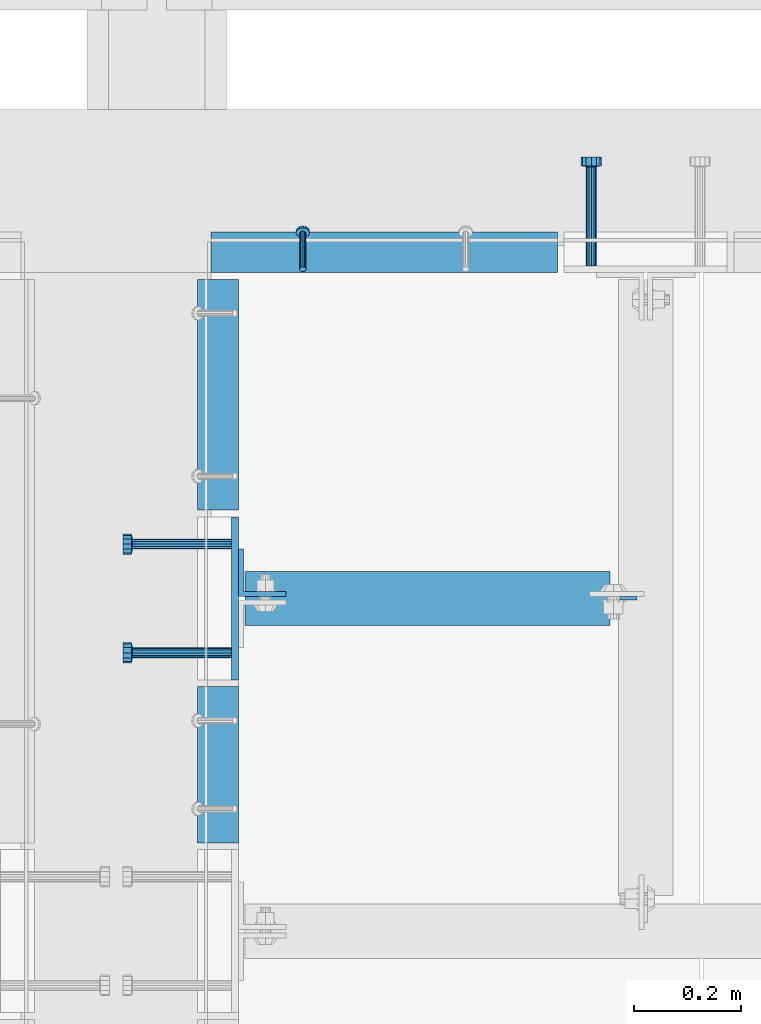
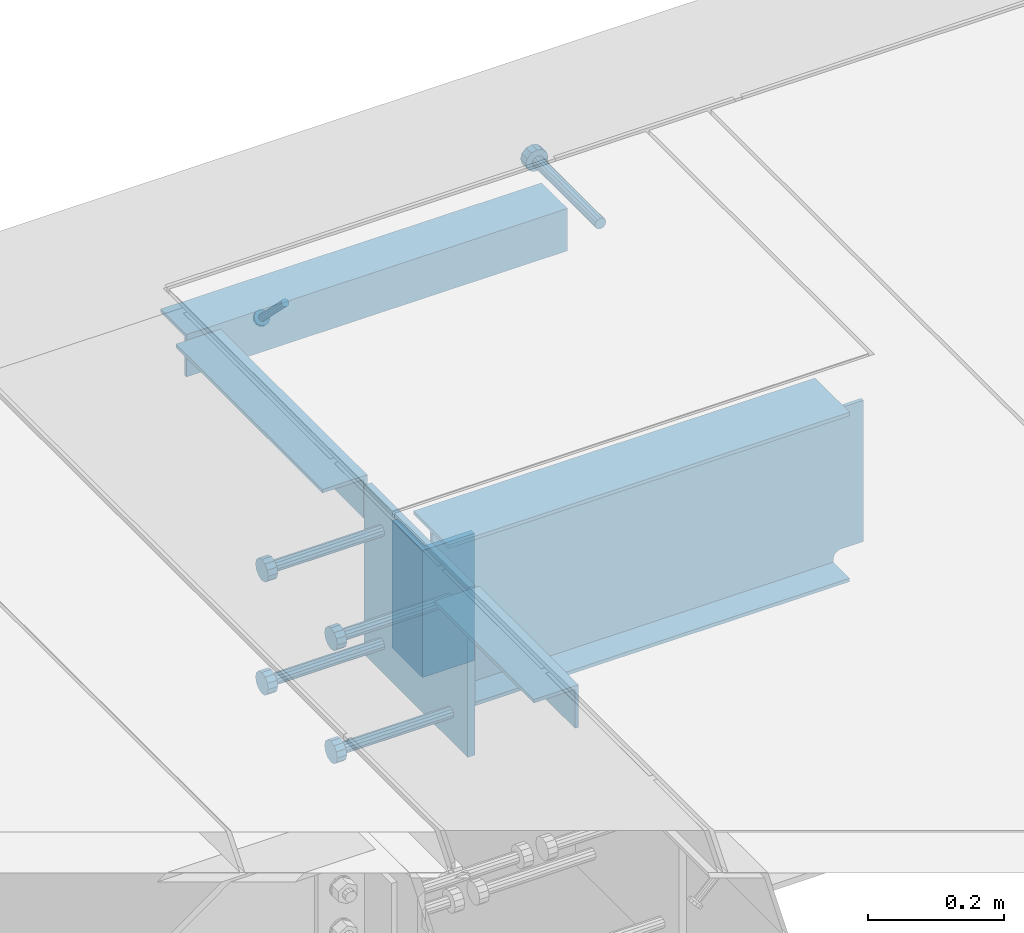
# One storey, part 2150 of 3843: 11 beams, 1 member, 6 elements without a shape of their own.
"""IFC2X3 building model written with IfcOpenShell, lengths in millimetres."""

from ifc_helpers import new_model, si_unit, frame, origin_with_axes, place, context, subcontext, project, spatial, faceted_brep, material, type_object, element, aggregate, save


model = new_model("IFC2X3")

# Units and contexts
model_context = context("Model", 3, precision=1e-05, world=origin_with_axes())
body_context = subcontext(model_context, "Body", "Model", "MODEL_VIEW")
ifc_project = project(units=[si_unit("LENGTHUNIT", "METRE", prefix="MILLI"), si_unit("AREAUNIT", "SQUARE_METRE"), si_unit("VOLUMEUNIT", "CUBIC_METRE"), si_unit("MASSUNIT", "GRAM", prefix="KILO"), si_unit("TIMEUNIT", "SECOND"), si_unit("PLANEANGLEUNIT", "RADIAN"), si_unit("SOLIDANGLEUNIT", "STERADIAN"), si_unit("THERMODYNAMICTEMPERATUREUNIT", "DEGREE_CELSIUS"), si_unit("LUMINOUSINTENSITYUNIT", "LUMEN")], contexts=[model_context])

# Site, building, storey
site_placement = place(None, origin_with_axes())
site = spatial("IfcSite", under=ifc_project, at=site_placement, CompositionType="ELEMENT")
building_placement = place(site_placement, origin_with_axes())
building = spatial("IfcBuilding", under=site, at=building_placement, Name="Undefined", CompositionType="ELEMENT")
storey_placement = place(building_placement, origin_with_axes())
storey = spatial("IfcBuildingStorey", under=building, at=storey_placement, Name="Undefined", CompositionType="ELEMENT", Elevation=0.0)

# Assembly, member
assembly_1_placement = place(storey_placement, origin_with_axes())
assembly_1 = element("IfcElementAssembly", 1, at=assembly_1_placement, inside=storey, Name="ANGLE", AssemblyPlace="NOTDEFINED", PredefinedType="RIGID_FRAME")
ifc_material_1 = material(Name="STEEL/A108")
member_type = type_object("IfcMemberType", PredefinedType="NOTDEFINED")
member_placement = place(assembly_1_placement, frame((62909.4499076102, 18697.5749559954, 30422.8500030518), z_axis=(-1.0, 0.0, 0.0), x_axis=(5.70000238222118e-08, 0.707106781186546, -0.707106781186546)))
member = element("IfcMember", 2, at=member_placement, type_object=member_type, material=ifc_material_1, Name="HEADED STUD ANCHOR", context=body_context, shape_type="Brep", body=[
    faceted_brep([(7.27595761418343e-12, -3.18000006675175, 5.5), (0.0, -5.49999999998363, 3.1800000667572), (94.4879985803855, -5.50000000011278, 3.1800000667572), (94.4879985803782, -3.18000006687362, 5.5), (0.0, -6.3499999046162, 0.0), (94.4879985803855, -6.34999990474535, 0.0), (0.0, -5.49999999998363, -3.1800000667572), (94.4879985803855, -5.50000000011278, -3.1800000667572), (7.27595761418343e-12, -3.18000006675175, -5.5), (94.4879985803782, -3.18000006687362, -5.5), (7.27595761418343e-12, -1.81898940354586e-12, -6.34999990463257), (94.4879985803782, -1.20053300634027e-10, -6.34999990463257), (0.0, 3.18000006675175, -5.5), (94.4879985803709, 3.18000006663351, -5.5), (7.27595761418343e-12, 5.49999999998363, -3.1800000667572), (94.4879985803709, 5.49999999987267, -3.1800000667572), (7.27595761418343e-12, 6.3499999046162, 0.0), (94.4879985803673, 6.34999990450706, 0.0), (7.27595761418343e-12, 5.49999999998363, 3.1800000667572), (94.4879985803709, 5.49999999987267, 3.1800000667572), (0.0, 3.18000006675175, 5.5), (94.4879985803709, 3.18000006663351, 5.5), (7.27595761418343e-12, -1.81898940354586e-12, 6.34999990463257), (94.4879985803782, -1.20053300634027e-10, 6.34999990463257), (96.5199985498621, -10.9899997712273, 6.34999990463257), (96.5199985498548, -6.34000015270249, 10.9899997711182), (96.5199985498621, -12.6999998093743, 0.0), (96.5199985498621, -10.9899997712273, -6.34999990463257), (96.5199985498548, -6.34000015270249, -10.9899997711182), (96.5199985498475, -1.21872290037572e-10, -12.6899995803833), (96.5199985498402, 6.34000015245874, -10.9899997711182), (96.519998549833, 10.9899997709817, -6.34999990463257), (96.519998549833, 12.6999998091305, 0.0), (96.519998549833, 10.9899997709817, 6.34999990463257), (96.5199985498402, 6.34000015245874, 10.9899997711182), (96.5199985498475, -1.21872290037572e-10, 12.6899995803833), (101.599998473539, -10.9899997712328, 6.34999990463257), (101.599998473532, -6.34000015270976, 10.9899997711182), (101.599998473539, -12.6999998093797, 0.0), (101.599998473539, -10.9899997712328, -6.34999990463257), (101.599998473532, -6.34000015270976, -10.9899997711182), (101.599998473524, -1.29148247651756e-10, -12.6899995803833), (101.599998473517, 6.34000015245329, -10.9899997711182), (101.59999847351, 10.9899997709763, -6.34999990463257), (101.599998473503, 12.6999998091196, 0.0), (101.59999847351, 10.9899997709763, 6.34999990463257), (101.599998473517, 6.34000015245329, 10.9899997711182), (101.599998473524, -1.29148247651756e-10, 12.6899995803833)], [[[0, 1, 2, 3]], [[1, 4, 5, 2]], [[4, 6, 7, 5]], [[6, 8, 9, 7]], [[8, 10, 11, 9]], [[10, 12, 13, 11]], [[12, 14, 15, 13]], [[14, 16, 17, 15]], [[16, 18, 19, 17]], [[18, 20, 21, 19]], [[20, 22, 23, 21]], [[22, 0, 3, 23]], [[22, 20, 18, 16, 14, 12, 10, 8, 6, 4, 1, 0]], [[3, 2, 24, 25]], [[2, 5, 26, 24]], [[5, 7, 27, 26]], [[7, 9, 28, 27]], [[9, 11, 29, 28]], [[11, 13, 30, 29]], [[13, 15, 31, 30]], [[15, 17, 32, 31]], [[17, 19, 33, 32]], [[19, 21, 34, 33]], [[21, 23, 35, 34]], [[23, 3, 25, 35]], [[25, 24, 36, 37]], [[24, 26, 38, 36]], [[26, 27, 39, 38]], [[27, 28, 40, 39]], [[28, 29, 41, 40]], [[29, 30, 42, 41]], [[30, 31, 43, 42]], [[31, 32, 44, 43]], [[32, 33, 45, 44]], [[33, 34, 46, 45]], [[34, 35, 47, 46]], [[35, 25, 37, 47]], [[38, 39, 40, 41, 42, 43, 44, 45, 46, 47, 37, 36]]]),
])

# Assembly, beam
assembly_2_placement = place(storey_placement, origin_with_axes())
assembly_2 = element("IfcElementAssembly", 3, at=assembly_2_placement, inside=storey, Name="EMBED PLATE", AssemblyPlace="NOTDEFINED", PredefinedType="RIGID_FRAME")
ifc_material_2 = material(Name="STEEL/A36")
beam_type_1 = type_object("IfcBeamType", PredefinedType="NOTDEFINED")
beam_1_placement = place(assembly_2_placement, frame((62782.4500030517, 18081.625, 30422.85), z_axis=(0.0, 1.0, 0.0), x_axis=(0.0, 0.0, -1.0)))
beam_1 = element("IfcBeam", 4, at=beam_1_placement, type_object=beam_type_1, material=ifc_material_2, Name="EMBED PLATE", context=body_context, shape_type="Brep", body=[
    faceted_brep([(-1.0550138540566e-10, 6.34999999999854, -152.400000000664), (1.0550138540566e-10, 6.34999999999854, 152.400000000656), (304.799999999999, 6.34999999999854, 152.400000000001), (304.799999999999, 6.34999999999854, -152.400000000001), (1.0550138540566e-10, -6.34999999999854, 152.400000000656), (304.799999999999, -6.34999999999854, 152.400000000001), (-1.0550138540566e-10, -6.34999999999854, -152.400000000664), (304.799999999999, -6.34999999999854, -152.400000000001)], [[[0, 1, 2, 3]], [[1, 4, 5, 2]], [[4, 6, 7, 5]], [[6, 0, 3, 7]], [[5, 7, 3, 2]], [[6, 4, 1, 0]]]),
])

assembly_3_placement = place(storey_placement, origin_with_axes())
assembly_3 = element("IfcElementAssembly", 5, at=assembly_3_placement, inside=storey, Name="ANGLE", AssemblyPlace="NOTDEFINED", PredefinedType="RIGID_FRAME")
beam_type_2 = type_object("IfcBeamType", Name="L3X3X1/4", PredefinedType="NOTDEFINED")
beam_2_placement = place(assembly_3_placement, frame((62750.6999970423, 17624.4250731787, 30391.1000045777), z_axis=(0.0, 0.0, -1.0), x_axis=(0.0, 1.0, 0.0)))
beam_2 = element("IfcBeam", 6, at=beam_2_placement, type_object=beam_type_2, material=ifc_material_2, Name="ANGLE", ObjectType="L3X3X1/4", context=body_context, shape_type="Brep", body=[
    faceted_brep([(0.0, 38.0999999999985, -38.0999999999985), (0.0, 38.0999999999985, 38.0999999999985), (292.099926759005, 38.0999999991764, 38.0999999999985), (292.099926759005, 38.0999999991764, -38.0999999999985), (0.0, 31.75, 38.0999999999985), (292.099926759009, 31.7499999991778, 38.0999999999985), (0.0, 31.75, -31.75), (292.099926759009, 31.7499999991778, -31.75), (0.0, -38.0999999999985, -31.75), (292.099926759067, -38.1000000008207, -31.75), (0.0, -38.0999999999985, -38.0999999999985), (292.099926759067, -38.1000000008207, -38.0999999999985)], [[[0, 1, 2, 3]], [[1, 4, 5, 2]], [[4, 6, 7, 5]], [[6, 8, 9, 7]], [[8, 10, 11, 9]], [[10, 0, 3, 11]], [[5, 7, 9, 11, 3, 2]], [[10, 8, 6, 4, 1, 0]]]),
])
aggregate(assembly_3, [beam_2])

# Beam
beam_3_placement = place(assembly_1_placement, frame((62737.999868244, 18729.324900916, 30391.1000030518), z_axis=(0.0, 0.0, -1.0), x_axis=(1.0, 0.0, 0.0)))
beam_3 = element("IfcBeam", 7, at=beam_3_placement, type_object=beam_type_2, material=ifc_material_2, Name="ANGLE", ObjectType="L3X3X1/4", context=body_context, shape_type="Brep", body=[
    faceted_brep([(0.0, 38.0999999999985, -38.0999999999985), (0.0, 38.0999999999985, 38.0999999999985), (647.700078732363, 38.0999999999985, 38.0999999999985), (647.700078732363, 38.0999999999985, -38.0999999999985), (0.0, 31.75, 38.0999999999985), (647.700078732363, 31.75, 38.0999999999985), (0.0, 31.75, -31.75), (647.700078732363, 31.75, -31.75), (0.0, -38.0999999999985, -31.75), (647.700078732363, -38.0999999999985, -31.75), (0.0, -38.0999999999985, -38.0999999999985), (647.700078732363, -38.0999999999985, -38.0999999999985)], [[[0, 1, 2, 3]], [[1, 4, 5, 2]], [[4, 6, 7, 5]], [[6, 8, 9, 7]], [[8, 10, 11, 9]], [[10, 0, 3, 11]], [[5, 7, 9, 11, 3, 2]], [[10, 8, 6, 4, 1, 0]]]),
])

aggregate(assembly_1, [member, beam_3])

# Assembly, beam
assembly_4_placement = place(storey_placement, origin_with_axes())
assembly_4 = element("IfcElementAssembly", 8, at=assembly_4_placement, inside=storey, Name="ANGLE", AssemblyPlace="NOTDEFINED", PredefinedType="RIGID_FRAME")
beam_4_placement = place(assembly_4_placement, frame((62750.6999970423, 18246.7250002667, 30391.1000045777), z_axis=(0.0, 0.0, -1.0), x_axis=(0.0, 1.0, 0.0)))
beam_4 = element("IfcBeam", 9, at=beam_4_placement, type_object=beam_type_2, material=ifc_material_2, Name="ANGLE", ObjectType="L3X3X1/4", context=body_context, shape_type="Brep", body=[
    faceted_brep([(0.0, 38.0999999999985, -38.0999999999985), (0.0, 38.0999999999985, 38.0999999999985), (431.800000000025, 38.0999999997803, 38.0999999999985), (431.800000000025, 38.0999999997803, -38.0999999999985), (0.0, 31.75, 38.0999999999985), (431.800000000021, 31.7499999997817, 38.0999999999985), (0.0, 31.75, -31.75), (431.800000000021, 31.7499999997817, -31.75), (0.0, -38.0999999999985, -31.75), (431.799999999981, -38.1000000002241, -31.75), (0.0, -38.0999999999985, -38.0999999999985), (431.799999999981, -38.1000000002241, -38.0999999999985)], [[[0, 1, 2, 3]], [[1, 4, 5, 2]], [[4, 6, 7, 5]], [[6, 8, 9, 7]], [[8, 10, 11, 9]], [[10, 0, 3, 11]], [[5, 7, 9, 11, 3, 2]], [[10, 8, 6, 4, 1, 0]]]),
])
aggregate(assembly_4, [beam_4])

assembly_5_placement = place(storey_placement, origin_with_axes())
assembly_5 = element("IfcElementAssembly", 10, at=assembly_5_placement, inside=storey, Name="BEAM", AssemblyPlace="NOTDEFINED", PredefinedType="RIGID_FRAME")
beam_type_3 = type_object("IfcBeamType", Name="L3-1/2X3-1/2X3/8", PredefinedType="NOTDEFINED")
beam_5_placement = place(assembly_5_placement, frame((62833.2500030518, 18129.25, 30391.1), z_axis=(0.0, 1.0, 0.0), x_axis=(0.0, 0.0, -1.0)))
beam_5 = element("IfcBeam", 11, at=beam_5_placement, type_object=beam_type_3, material=ifc_material_2, Name="ANGLE", ObjectType="L3-1/2X3-1/2X3/8", context=body_context, shape_type="Brep", body=[
    faceted_brep([(-3.63797880709171e-12, 44.4499999999971, -44.4500000000007), (-3.63797880709171e-12, 44.4499999999971, 44.4500000000007), (228.600000000006, 44.4499999999971, 44.4500000000007), (228.600000000006, 44.4499999999971, -44.4500000000007), (0.0, 34.9250000000029, 44.4500000000007), (228.600000000006, 34.9250000000029, 44.4500000000007), (0.0, 34.9250000000029, -34.9250000000029), (228.600000000006, 34.9250000000029, -34.9249999999993), (0.0, -44.4499999999971, -34.9249999999993), (228.600000000006, -44.4499999999971, -34.9249999999993), (3.63797880709171e-12, -44.4499999999971, -44.4500000000007), (228.600000000006, -44.4499999999971, -44.4500000000007)], [[[0, 1, 2, 3]], [[1, 4, 5, 2]], [[4, 6, 7, 5]], [[6, 8, 9, 7]], [[8, 10, 11, 9]], [[10, 0, 3, 11]], [[5, 7, 9, 11, 3, 2]], [[10, 8, 6, 4, 1, 0]]]),
])

# Beam
beam_type_4 = type_object("IfcBeamType", PredefinedType="NOTDEFINED")
beam_6_placement = place(assembly_2_placement, frame((62776.1000030517, 17980.025, 30372.05), z_axis=(0.0, -1.0, 0.0), x_axis=(-1.0, 0.0, 0.0)))
beam_6 = element("IfcBeam", 12, at=beam_6_placement, type_object=beam_type_4, material=ifc_material_1, Name="HEADED STUD ANCHOR", context=body_context, shape_type="Brep", body=[
    faceted_brep([(0.0, -9.52000045776367, 0.0), (0.0, -8.25, -4.76000022888184), (184.912000000004, -8.25, -4.76000022888184), (184.912000000004, -9.52000045776367, 0.0), (0.0, -4.76000022888184, -8.25), (184.912000000004, -4.76000022888184, -8.25), (0.0, 0.0, -9.52000045776367), (184.912000000004, 0.0, -9.52000045776367), (0.0, 4.76000022888184, -8.25), (184.912000000004, 4.76000022888184, -8.25), (0.0, 8.25, -4.76000022888184), (184.912000000004, 8.25, -4.76000022888184), (0.0, 9.52000045776367, 0.0), (184.912000000004, 9.52000045776367, 0.0), (0.0, 8.25, 4.76000022888184), (184.912000000004, 8.25, 4.76000022888184), (0.0, 4.76000022888184, 8.25), (184.912000000004, 4.76000022888184, 8.25), (0.0, 0.0, 9.52000045776367), (184.912000000004, 0.0, 9.52000045776367), (0.0, -4.76000022888184, 8.25), (184.912000000004, -4.76000022888184, 8.25), (0.0, -8.25, 4.76000022888184), (184.912000000004, -8.25, 4.76000022888184), (186.944000000003, -16.5, -9.52000045776367), (186.944000000003, -19.0499992370605, 0.0), (186.944000000003, -9.52000045776367, -16.5), (186.944000000003, 0.0, -19.0499992370605), (186.944000000003, 9.52000045776367, -16.5), (186.944000000003, 16.5, -9.52000045776367), (186.944000000003, 19.0499992370605, 0.0), (186.944000000003, 16.5, 9.52000045776367), (186.944000000003, 9.52000045776367, 16.5), (186.944000000003, 0.0, 19.0499992370605), (186.944000000003, -9.52000045776367, 16.5), (186.944000000003, -16.5, 9.52000045776367), (203.199999999997, -16.5, -9.52000045776367), (203.199999999997, -19.0499992370605, 0.0), (203.199999999997, -9.52000045776367, -16.5), (203.199999999997, 0.0, -19.0499992370605), (203.199999999997, 9.52000045776367, -16.5), (203.199999999997, 16.5, -9.52000045776367), (203.199999999997, 19.0499992370605, 0.0), (203.199999999997, 16.5, 9.52000045776367), (203.199999999997, 9.52000045776367, 16.5), (203.199999999997, 0.0, 19.0499992370605), (203.199999999997, -9.52000045776367, 16.5), (203.199999999997, -16.5, 9.52000045776367)], [[[0, 1, 2, 3]], [[1, 4, 5, 2]], [[4, 6, 7, 5]], [[6, 8, 9, 7]], [[8, 10, 11, 9]], [[10, 12, 13, 11]], [[12, 14, 15, 13]], [[14, 16, 17, 15]], [[16, 18, 19, 17]], [[18, 20, 21, 19]], [[20, 22, 23, 21]], [[22, 0, 3, 23]], [[22, 20, 18, 16, 14, 12, 10, 8, 6, 4, 1, 0]], [[3, 2, 24, 25]], [[2, 5, 26, 24]], [[5, 7, 27, 26]], [[7, 9, 28, 27]], [[9, 11, 29, 28]], [[11, 13, 30, 29]], [[13, 15, 31, 30]], [[15, 17, 32, 31]], [[17, 19, 33, 32]], [[19, 21, 34, 33]], [[21, 23, 35, 34]], [[23, 3, 25, 35]], [[25, 24, 36, 37]], [[24, 26, 38, 36]], [[26, 27, 39, 38]], [[27, 28, 40, 39]], [[28, 29, 41, 40]], [[29, 30, 42, 41]], [[30, 31, 43, 42]], [[31, 32, 44, 43]], [[32, 33, 45, 44]], [[33, 34, 46, 45]], [[34, 35, 47, 46]], [[35, 25, 37, 47]], [[38, 39, 40, 41, 42, 43, 44, 45, 46, 47, 37, 36]]]),
])

beam_7_placement = place(assembly_2_placement, frame((62776.1000030517, 17980.025, 30168.85), z_axis=(0.0, -1.0, 0.0), x_axis=(-1.0, 0.0, 0.0)))
beam_7 = element("IfcBeam", 13, at=beam_7_placement, type_object=beam_type_4, material=ifc_material_1, Name="HEADED STUD ANCHOR", context=body_context, shape_type="Brep", body=[
    faceted_brep([(0.0, -9.52000045776367, 0.0), (0.0, -8.25, -4.76000022888184), (184.912000000004, -8.25, -4.76000022888184), (184.912000000004, -9.52000045776367, 0.0), (0.0, -4.76000022888184, -8.25), (184.912000000004, -4.76000022888184, -8.25), (0.0, 0.0, -9.52000045776367), (184.912000000004, 0.0, -9.52000045776367), (0.0, 4.76000022888184, -8.25), (184.912000000004, 4.76000022888184, -8.25), (0.0, 8.25, -4.76000022888184), (184.912000000004, 8.25, -4.76000022888184), (0.0, 9.52000045776367, 0.0), (184.912000000004, 9.52000045776367, 0.0), (0.0, 8.25, 4.76000022888184), (184.912000000004, 8.25, 4.76000022888184), (0.0, 4.76000022888184, 8.25), (184.912000000004, 4.76000022888184, 8.25), (0.0, 0.0, 9.52000045776367), (184.912000000004, 0.0, 9.52000045776367), (0.0, -4.76000022888184, 8.25), (184.912000000004, -4.76000022888184, 8.25), (0.0, -8.25, 4.76000022888184), (184.912000000004, -8.25, 4.76000022888184), (186.944000000003, -16.5, -9.52000045776367), (186.944000000003, -19.0499992370605, 0.0), (186.944000000003, -9.52000045776367, -16.5), (186.944000000003, 0.0, -19.0499992370605), (186.944000000003, 9.52000045776367, -16.5), (186.944000000003, 16.5, -9.52000045776367), (186.944000000003, 19.0499992370605, 0.0), (186.944000000003, 16.5, 9.52000045776367), (186.944000000003, 9.52000045776367, 16.5), (186.944000000003, 0.0, 19.0499992370605), (186.944000000003, -9.52000045776367, 16.5), (186.944000000003, -16.5, 9.52000045776367), (203.199999999997, -16.5, -9.52000045776367), (203.199999999997, -19.0499992370605, 0.0), (203.199999999997, -9.52000045776367, -16.5), (203.199999999997, 0.0, -19.0499992370605), (203.199999999997, 9.52000045776367, -16.5), (203.199999999997, 16.5, -9.52000045776367), (203.199999999997, 19.0499992370605, 0.0), (203.199999999997, 16.5, 9.52000045776367), (203.199999999997, 9.52000045776367, 16.5), (203.199999999997, 0.0, 19.0499992370605), (203.199999999997, -9.52000045776367, 16.5), (203.199999999997, -16.5, 9.52000045776367)], [[[0, 1, 2, 3]], [[1, 4, 5, 2]], [[4, 6, 7, 5]], [[6, 8, 9, 7]], [[8, 10, 11, 9]], [[10, 12, 13, 11]], [[12, 14, 15, 13]], [[14, 16, 17, 15]], [[16, 18, 19, 17]], [[18, 20, 21, 19]], [[20, 22, 23, 21]], [[22, 0, 3, 23]], [[22, 20, 18, 16, 14, 12, 10, 8, 6, 4, 1, 0]], [[3, 2, 24, 25]], [[2, 5, 26, 24]], [[5, 7, 27, 26]], [[7, 9, 28, 27]], [[9, 11, 29, 28]], [[11, 13, 30, 29]], [[13, 15, 31, 30]], [[15, 17, 32, 31]], [[17, 19, 33, 32]], [[19, 21, 34, 33]], [[21, 23, 35, 34]], [[23, 3, 25, 35]], [[25, 24, 36, 37]], [[24, 26, 38, 36]], [[26, 27, 39, 38]], [[27, 28, 40, 39]], [[28, 29, 41, 40]], [[29, 30, 42, 41]], [[30, 31, 43, 42]], [[31, 32, 44, 43]], [[32, 33, 45, 44]], [[33, 34, 46, 45]], [[34, 35, 47, 46]], [[35, 25, 37, 47]], [[38, 39, 40, 41, 42, 43, 44, 45, 46, 47, 37, 36]]]),
])

beam_8_placement = place(assembly_2_placement, frame((62776.1000030517, 18183.225, 30372.05), z_axis=(0.0, -1.0, 0.0), x_axis=(-1.0, 0.0, 0.0)))
beam_8 = element("IfcBeam", 14, at=beam_8_placement, type_object=beam_type_4, material=ifc_material_2, Name="PLATE", context=body_context, shape_type="Brep", body=[
    faceted_brep([(0.0, -9.52000045776367, 0.0), (0.0, -8.25, -4.76000022888184), (184.912000000004, -8.25, -4.76000022888184), (184.912000000004, -9.52000045776367, 0.0), (0.0, -4.76000022888184, -8.25), (184.912000000004, -4.76000022888184, -8.25), (0.0, 0.0, -9.52000045776367), (184.912000000004, 0.0, -9.52000045776367), (0.0, 4.76000022888184, -8.25), (184.912000000004, 4.76000022888184, -8.25), (0.0, 8.25, -4.76000022888184), (184.912000000004, 8.25, -4.76000022888184), (0.0, 9.52000045776367, 0.0), (184.912000000004, 9.52000045776367, 0.0), (0.0, 8.25, 4.76000022888184), (184.912000000004, 8.25, 4.76000022888184), (0.0, 4.76000022888184, 8.25), (184.912000000004, 4.76000022888184, 8.25), (0.0, 0.0, 9.52000045776367), (184.912000000004, 0.0, 9.52000045776367), (0.0, -4.76000022888184, 8.25), (184.912000000004, -4.76000022888184, 8.25), (0.0, -8.25, 4.76000022888184), (184.912000000004, -8.25, 4.76000022888184), (186.944000000003, -16.5, -9.52000045776367), (186.944000000003, -19.0499992370605, 0.0), (186.944000000003, -9.52000045776367, -16.5), (186.944000000003, 0.0, -19.0499992370605), (186.944000000003, 9.52000045776367, -16.5), (186.944000000003, 16.5, -9.52000045776367), (186.944000000003, 19.0499992370605, 0.0), (186.944000000003, 16.5, 9.52000045776367), (186.944000000003, 9.52000045776367, 16.5), (186.944000000003, 0.0, 19.0499992370605), (186.944000000003, -9.52000045776367, 16.5), (186.944000000003, -16.5, 9.52000045776367), (203.199999999997, -16.5, -9.52000045776367), (203.199999999997, -19.0499992370605, 0.0), (203.199999999997, -9.52000045776367, -16.5), (203.199999999997, 0.0, -19.0499992370605), (203.199999999997, 9.52000045776367, -16.5), (203.199999999997, 16.5, -9.52000045776367), (203.199999999997, 19.0499992370605, 0.0), (203.199999999997, 16.5, 9.52000045776367), (203.199999999997, 9.52000045776367, 16.5), (203.199999999997, 0.0, 19.0499992370605), (203.199999999997, -9.52000045776367, 16.5), (203.199999999997, -16.5, 9.52000045776367)], [[[0, 1, 2, 3]], [[1, 4, 5, 2]], [[4, 6, 7, 5]], [[6, 8, 9, 7]], [[8, 10, 11, 9]], [[10, 12, 13, 11]], [[12, 14, 15, 13]], [[14, 16, 17, 15]], [[16, 18, 19, 17]], [[18, 20, 21, 19]], [[20, 22, 23, 21]], [[22, 0, 3, 23]], [[22, 20, 18, 16, 14, 12, 10, 8, 6, 4, 1, 0]], [[3, 2, 24, 25]], [[2, 5, 26, 24]], [[5, 7, 27, 26]], [[7, 9, 28, 27]], [[9, 11, 29, 28]], [[11, 13, 30, 29]], [[13, 15, 31, 30]], [[15, 17, 32, 31]], [[17, 19, 33, 32]], [[19, 21, 34, 33]], [[21, 23, 35, 34]], [[23, 3, 25, 35]], [[25, 24, 36, 37]], [[24, 26, 38, 36]], [[26, 27, 39, 38]], [[27, 28, 40, 39]], [[28, 29, 41, 40]], [[29, 30, 42, 41]], [[30, 31, 43, 42]], [[31, 32, 44, 43]], [[32, 33, 45, 44]], [[33, 34, 46, 45]], [[34, 35, 47, 46]], [[35, 25, 37, 47]], [[38, 39, 40, 41, 42, 43, 44, 45, 46, 47, 37, 36]]]),
])

beam_9_placement = place(assembly_2_placement, frame((62776.1000030517, 18183.225, 30168.85), z_axis=(0.0, -1.0, 0.0), x_axis=(-1.0, 0.0, 0.0)))
beam_9 = element("IfcBeam", 15, at=beam_9_placement, type_object=beam_type_4, material=ifc_material_1, Name="HEADED STUD ANCHOR", context=body_context, shape_type="Brep", body=[
    faceted_brep([(0.0, -9.52000045776367, 0.0), (0.0, -8.25, -4.76000022888184), (184.912000000004, -8.25, -4.76000022888184), (184.912000000004, -9.52000045776367, 0.0), (0.0, -4.76000022888184, -8.25), (184.912000000004, -4.76000022888184, -8.25), (0.0, 0.0, -9.52000045776367), (184.912000000004, 0.0, -9.52000045776367), (0.0, 4.76000022888184, -8.25), (184.912000000004, 4.76000022888184, -8.25), (0.0, 8.25, -4.76000022888184), (184.912000000004, 8.25, -4.76000022888184), (0.0, 9.52000045776367, 0.0), (184.912000000004, 9.52000045776367, 0.0), (0.0, 8.25, 4.76000022888184), (184.912000000004, 8.25, 4.76000022888184), (0.0, 4.76000022888184, 8.25), (184.912000000004, 4.76000022888184, 8.25), (0.0, 0.0, 9.52000045776367), (184.912000000004, 0.0, 9.52000045776367), (0.0, -4.76000022888184, 8.25), (184.912000000004, -4.76000022888184, 8.25), (0.0, -8.25, 4.76000022888184), (184.912000000004, -8.25, 4.76000022888184), (186.944000000003, -16.5, -9.52000045776367), (186.944000000003, -19.0499992370605, 0.0), (186.944000000003, -9.52000045776367, -16.5), (186.944000000003, 0.0, -19.0499992370605), (186.944000000003, 9.52000045776367, -16.5), (186.944000000003, 16.5, -9.52000045776367), (186.944000000003, 19.0499992370605, 0.0), (186.944000000003, 16.5, 9.52000045776367), (186.944000000003, 9.52000045776367, 16.5), (186.944000000003, 0.0, 19.0499992370605), (186.944000000003, -9.52000045776367, 16.5), (186.944000000003, -16.5, 9.52000045776367), (203.199999999997, -16.5, -9.52000045776367), (203.199999999997, -19.0499992370605, 0.0), (203.199999999997, -9.52000045776367, -16.5), (203.199999999997, 0.0, -19.0499992370605), (203.199999999997, 9.52000045776367, -16.5), (203.199999999997, 16.5, -9.52000045776367), (203.199999999997, 19.0499992370605, 0.0), (203.199999999997, 16.5, 9.52000045776367), (203.199999999997, 9.52000045776367, 16.5), (203.199999999997, 0.0, 19.0499992370605), (203.199999999997, -9.52000045776367, 16.5), (203.199999999997, -16.5, 9.52000045776367)], [[[0, 1, 2, 3]], [[1, 4, 5, 2]], [[4, 6, 7, 5]], [[6, 8, 9, 7]], [[8, 10, 11, 9]], [[10, 12, 13, 11]], [[12, 14, 15, 13]], [[14, 16, 17, 15]], [[16, 18, 19, 17]], [[18, 20, 21, 19]], [[20, 22, 23, 21]], [[22, 0, 3, 23]], [[22, 20, 18, 16, 14, 12, 10, 8, 6, 4, 1, 0]], [[3, 2, 24, 25]], [[2, 5, 26, 24]], [[5, 7, 27, 26]], [[7, 9, 28, 27]], [[9, 11, 29, 28]], [[11, 13, 30, 29]], [[13, 15, 31, 30]], [[15, 17, 32, 31]], [[17, 19, 33, 32]], [[19, 21, 34, 33]], [[21, 23, 35, 34]], [[23, 3, 25, 35]], [[25, 24, 36, 37]], [[24, 26, 38, 36]], [[26, 27, 39, 38]], [[27, 28, 40, 39]], [[28, 29, 41, 40]], [[29, 30, 42, 41]], [[30, 31, 43, 42]], [[31, 32, 44, 43]], [[32, 33, 45, 44]], [[33, 34, 46, 45]], [[34, 35, 47, 46]], [[35, 25, 37, 47]], [[38, 39, 40, 41, 42, 43, 44, 45, 46, 47, 37, 36]]]),
])

aggregate(assembly_2, [beam_6, beam_7, beam_8, beam_9, beam_1])

# Assembly, beam
assembly_6_placement = place(storey_placement, origin_with_axes())
assembly_6 = element("IfcElementAssembly", 16, at=assembly_6_placement, inside=storey, Name="EMBED PLATE", AssemblyPlace="NOTDEFINED", PredefinedType="RIGID_FRAME")
beam_10_placement = place(assembly_6_placement, frame((63449.2, 18703.9249969482, 30372.05), z_axis=(-1.0, 0.0, 0.0), x_axis=(0.0, 1.0, 0.0)))
beam_10 = element("IfcBeam", 17, at=beam_10_placement, type_object=beam_type_4, material=ifc_material_1, Name="HEADED STUD ANCHOR", context=body_context, shape_type="Brep", body=[
    faceted_brep([(0.0, -9.52000045776367, 0.0), (0.0, -8.25, -4.76000022888184), (184.912000000004, -8.25, -4.76000022888184), (184.912000000004, -9.52000045776367, 0.0), (0.0, -4.76000022888184, -8.25), (184.912000000004, -4.76000022888184, -8.25), (0.0, 0.0, -9.52000045776367), (184.912000000004, 0.0, -9.52000045776367), (0.0, 4.76000022888184, -8.25), (184.912000000004, 4.76000022888184, -8.25), (0.0, 8.25, -4.76000022888184), (184.912000000004, 8.25, -4.76000022888184), (0.0, 9.52000045776367, 0.0), (184.912000000004, 9.52000045776367, 0.0), (0.0, 8.25, 4.76000022888184), (184.912000000004, 8.25, 4.76000022888184), (0.0, 4.76000022888184, 8.25), (184.912000000004, 4.76000022888184, 8.25), (0.0, 0.0, 9.52000045776367), (184.912000000004, 0.0, 9.52000045776367), (0.0, -4.76000022888184, 8.25), (184.912000000004, -4.76000022888184, 8.25), (0.0, -8.25, 4.76000022888184), (184.912000000004, -8.25, 4.76000022888184), (186.944000000003, -16.5, -9.52000045776367), (186.944000000003, -19.0499992370605, 0.0), (186.944000000003, -9.52000045776367, -16.5), (186.944000000003, 0.0, -19.0499992370605), (186.944000000003, 9.52000045776367, -16.5), (186.944000000003, 16.5, -9.52000045776367), (186.944000000003, 19.0499992370605, 0.0), (186.944000000003, 16.5, 9.52000045776367), (186.944000000003, 9.52000045776367, 16.5), (186.944000000003, 0.0, 19.0499992370605), (186.944000000003, -9.52000045776367, 16.5), (186.944000000003, -16.5, 9.52000045776367), (203.199999999997, -16.5, -9.52000045776367), (203.199999999997, -19.0499992370605, 0.0), (203.199999999997, -9.52000045776367, -16.5), (203.199999999997, 0.0, -19.0499992370605), (203.199999999997, 9.52000045776367, -16.5), (203.199999999997, 16.5, -9.52000045776367), (203.199999999997, 19.0499992370605, 0.0), (203.199999999997, 16.5, 9.52000045776367), (203.199999999997, 9.52000045776367, 16.5), (203.199999999997, 0.0, 19.0499992370605), (203.199999999997, -9.52000045776367, 16.5), (203.199999999997, -16.5, 9.52000045776367)], [[[0, 1, 2, 3]], [[1, 4, 5, 2]], [[4, 6, 7, 5]], [[6, 8, 9, 7]], [[8, 10, 11, 9]], [[10, 12, 13, 11]], [[12, 14, 15, 13]], [[14, 16, 17, 15]], [[16, 18, 19, 17]], [[18, 20, 21, 19]], [[20, 22, 23, 21]], [[22, 0, 3, 23]], [[22, 20, 18, 16, 14, 12, 10, 8, 6, 4, 1, 0]], [[3, 2, 24, 25]], [[2, 5, 26, 24]], [[5, 7, 27, 26]], [[7, 9, 28, 27]], [[9, 11, 29, 28]], [[11, 13, 30, 29]], [[13, 15, 31, 30]], [[15, 17, 32, 31]], [[17, 19, 33, 32]], [[19, 21, 34, 33]], [[21, 23, 35, 34]], [[23, 3, 25, 35]], [[25, 24, 36, 37]], [[24, 26, 38, 36]], [[26, 27, 39, 38]], [[27, 28, 40, 39]], [[28, 29, 41, 40]], [[29, 30, 42, 41]], [[30, 31, 43, 42]], [[31, 32, 44, 43]], [[32, 33, 45, 44]], [[33, 34, 46, 45]], [[34, 35, 47, 46]], [[35, 25, 37, 47]], [[38, 39, 40, 41, 42, 43, 44, 45, 46, 47, 37, 36]]]),
])
aggregate(assembly_6, [beam_10])

# Beam
ifc_material_3 = material(Name="STEEL/A992")
beam_type_5 = type_object("IfcBeamType", Name="W12X16", PredefinedType="NOTDEFINED")
beam_11_placement = place(assembly_5_placement, frame((62788.8, 18081.625, 30276.8), z_axis=(0.0, 0.0, 1.0), x_axis=(1.0, 0.0, 0.0)))
beam_11 = element("IfcBeam", 18, at=beam_11_placement, type_object=beam_type_5, material=ifc_material_3, Name="BEAM", ObjectType="W12X16", context=body_context, shape_type="Brep", body=[
    faceted_brep([(695.324999999997, -3.17499999999927, -146.049999999999), (695.324999999997, -50.7999999999993, -146.049999999999), (695.324999999997, -50.7999999999993, -152.400000000001), (695.324999999997, 50.7999999999993, -152.400000000001), (695.324999999997, 50.7999999999993, -146.049999999999), (695.324999999997, 3.17499999999927, -146.049999999999), (695.324999999997, 3.17499999999927, -139.699999809265), (695.324999999997, -3.17499999999927, -139.699999809265), (696.291729922588, 3.17499999999927, -134.839920291219), (696.291729922588, -3.17499999999927, -134.839920291219), (699.044743823062, 3.17499999999927, -130.719743823065), (699.044743823062, -3.17499999999927, -130.719743823065), (703.164920291216, 3.17499999999927, -127.966729922588), (703.164920291216, -3.17499999999927, -127.966729922588), (708.024999809262, 3.17499999999927, -127.0), (708.024999809262, -3.17499999999927, -127.0), (746.125, -3.17499999999927, -127.0), (746.125, 3.17499999999927, -127.0), (12.7000000064072, 3.17500000014843, 146.04999999977), (12.7000030517593, 50.7999999999993, 146.049999999999), (695.324999999997, 50.7999999999993, 146.049999999999), (695.324999999997, 3.17499999999927, 146.049999999999), (12.7000030517593, -50.7999999999993, -152.400000000001), (12.7000030517593, -50.7999999999993, -146.049999999999), (12.7000000064072, -3.17500000016298, -146.049999999763), (12.7000000064072, -3.17499999987194, 146.049999999777), (12.7000030517593, -50.7999999999993, 146.049999999999), (12.7000030517593, -50.7999999999993, 152.400000000001), (12.7000030517593, 50.7999999999993, 152.400000000001), (12.7000000064072, 3.17499999985739, -146.049999999763), (12.7000030517593, 50.7999999999993, -146.049999999999), (12.7000030517593, 50.7999999999993, -152.400000000001), (695.324999999997, -3.17499999999927, 146.049999999999), (695.324999999997, -50.7999999999993, 146.049999999999), (695.324999999997, -50.7999999999993, 152.400000000001), (695.324999999997, 50.7999999999993, 152.400000000001), (695.324999999997, -3.17499999999927, 139.699999809265), (695.324999999997, 3.17499999999927, 139.699999809265), (696.291729922588, -3.17499999999927, 134.839920291219), (696.291729922588, 3.17499999999927, 134.839920291219), (699.044743823062, -3.17499999999927, 130.719743823065), (699.044743823062, 3.17499999999927, 130.719743823065), (703.164920291216, -3.17499999999927, 127.966729922588), (703.164920291216, 3.17499999999927, 127.966729922588), (708.024999809262, -3.17499999999927, 127.0), (708.024999809262, 3.17499999999927, 127.0), (746.125, -3.17499999999927, 127.0), (746.125, 3.17499999999927, 127.0), (746.125, 3.17499999999927, -116.299999999999), (746.125, 3.17499999999927, 114.299999999999)], [[[0, 1, 2, 3, 4, 5, 6, 7]], [[7, 6, 8, 9]], [[9, 8, 10, 11]], [[11, 10, 12, 13]], [[13, 12, 14, 15]], [[16, 15, 14, 17]], [[18, 19, 20, 21]], [[22, 23, 24, 25, 26, 27, 28, 19, 18, 29, 30, 31]], [[26, 25, 32, 33]], [[27, 26, 33, 34]], [[28, 27, 34, 35]], [[19, 28, 35, 20]], [[34, 33, 32, 36, 37, 21, 20, 35]], [[38, 39, 37, 36]], [[40, 41, 39, 38]], [[42, 43, 41, 40]], [[44, 45, 43, 42]], [[46, 47, 45, 44]], [[48, 49, 47, 46, 16, 17]], [[12, 10, 8, 6, 5, 29, 18, 21, 37, 39, 41, 43, 45, 47, 49, 48, 17, 14]], [[30, 29, 5, 4]], [[31, 30, 4, 3]], [[22, 31, 3, 2]], [[23, 22, 2, 1]], [[24, 23, 1, 0]], [[46, 44, 42, 40, 38, 36, 32, 25, 24, 0, 7, 9, 11, 13, 15, 16]]]),
])

aggregate(assembly_5, [beam_5, beam_11])

save(model, "model.ifc")
